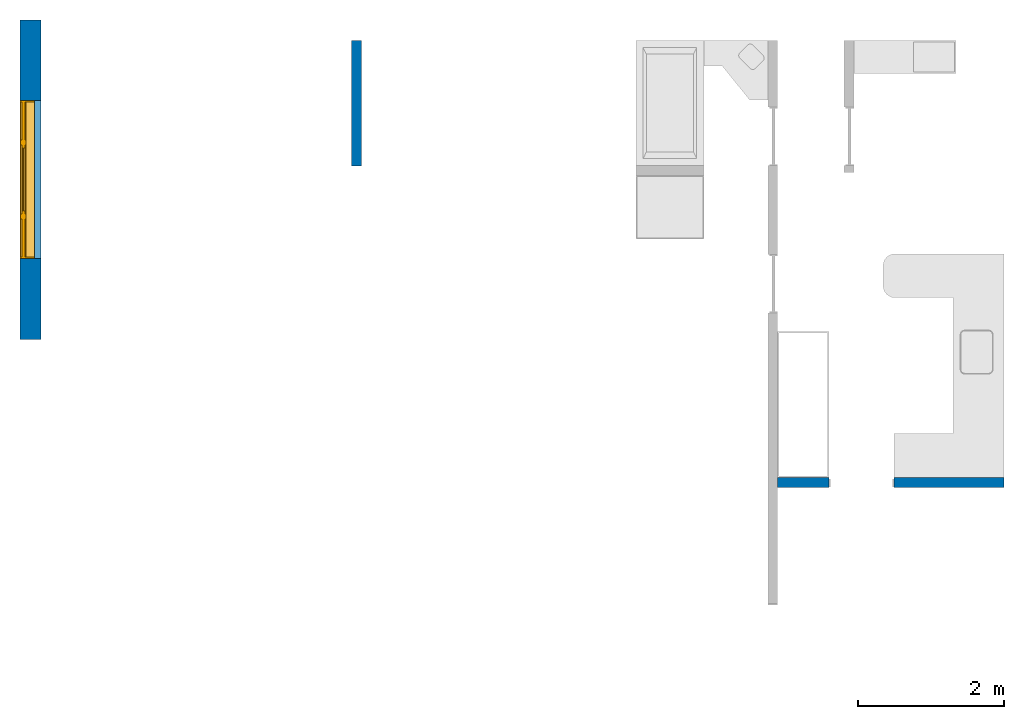
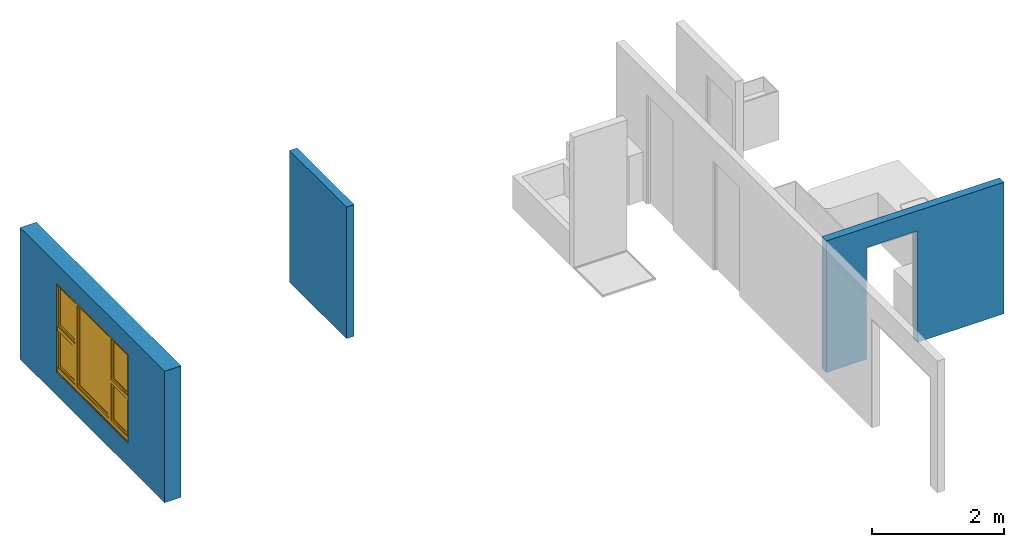
# One storey, part 1 of 6: 3 walls, 1 window, 2 openings.
"""IFC4 building model written with IfcOpenShell, lengths in millimetres."""

import ifcopenshell
import ifcopenshell.guid

model = None  # the IFC model being written
_history = None  # IfcOwnerHistory: only IFC2X3 demands one
_inside = {}  # id of a spatial element -> (the spatial element, [elements in it])
_under = {}  # id of a project, library or spatial element -> (it, [spatial elements below it])
_declared = {}  # id of a project -> (the project, [libraries it declares])
_typed = {}  # id of a type object -> (the type object, [elements of that type])
_made_of = {}  # id of a material, layer set ... -> (it, [elements and type objects made of it])


def new_model(schema):
    """Start an empty IFC model of exactly this schema.

    Asked for "IFC4X3", IfcOpenShell would pick the latest addendum, in which some entities
    have other attributes; the version numbers below select the first issue.
    IFC2X3 requires an IfcOwnerHistory on every rooted entity: one is made here for all.
    """
    global model, _history
    if schema == "IFC4X3":
        model = ifcopenshell.file(schema_version=(4, 3, 0, 0))
    else:
        model = ifcopenshell.file(schema=schema)
    _inside.clear()
    _under.clear()
    _declared.clear()
    _typed.clear()
    _made_of.clear()
    _history = None
    if model.schema == "IFC2X3":
        org = make("IfcOrganization", Name="unknown")
        user = make(
            "IfcPersonAndOrganization",
            ThePerson=make("IfcPerson", FamilyName="unknown"),
            TheOrganization=org,
        )
        app = make(
            "IfcApplication",
            ApplicationDeveloper=org,
            Version="unknown",
            ApplicationFullName="unknown",
            ApplicationIdentifier="unknown",
        )
        _history = make(
            "IfcOwnerHistory",
            OwningUser=user,
            OwningApplication=app,
            ChangeAction="ADDED",
            CreationDate=0,
        )
    return model


def make(cls, **values):
    """One entity of the class cls with the attributes given. An attribute that is None is left unset."""
    return model.create_entity(
        cls, **{name: value for name, value in values.items() if value is not None}
    )


def entity(cls, *values):
    """Any entity or typed value of the class cls, its attributes in the order of the schema. None: left unset."""
    e = model.create_entity(cls)
    for i, value in enumerate(values):
        if value is not None:
            e[i] = value
    return e


def rooted(cls, **values):
    """An entity with a GlobalId (a new one), such as an element, a storey or a relation."""
    return make(cls, GlobalId=ifcopenshell.guid.new(), OwnerHistory=_history, **values)


def si_unit(unit_type, name, prefix=None):
    """IfcSIUnit, for example si_unit("LENGTHUNIT", "METRE", prefix="MILLI")."""
    return make("IfcSIUnit", UnitType=unit_type, Prefix=prefix, Name=name)


def converted_unit(unit_type, name, factor, base, dimensions=None, offset=None):
    """IfcConversionBasedUnit, such as the inch: factor (a typed value) times the base unit."""
    return make(
        "IfcConversionBasedUnit"
        if offset is None
        else "IfcConversionBasedUnitWithOffset",
        ConversionOffset=offset,
        Dimensions=None
        if dimensions is None
        else entity("IfcDimensionalExponents", *dimensions),
        UnitType=unit_type,
        Name=name,
        ConversionFactor=make(
            "IfcMeasureWithUnit", ValueComponent=factor, UnitComponent=base
        ),
    )


def assignment(units):
    """IfcUnitAssignment: the units of a project."""
    return None if units is None else make("IfcUnitAssignment", Units=units)


def point(xyz):
    """IfcCartesianPoint."""
    return None if xyz is None else make("IfcCartesianPoint", Coordinates=xyz)


def direction(xyz):
    """IfcDirection."""
    return None if xyz is None else make("IfcDirection", DirectionRatios=xyz)


def frame(location, z_axis=None, x_axis=None):
    """IfcAxis2Placement3D, a coordinate frame: its origin and axes. An axis left out is left unset."""
    return make(
        "IfcAxis2Placement3D",
        Location=point(location),
        Axis=direction(z_axis),
        RefDirection=direction(x_axis),
    )


def frame_2d(location, x_axis=None):
    """IfcAxis2Placement2D, a coordinate frame in the plane: its origin and x axis."""
    return make(
        "IfcAxis2Placement2D", Location=point(location), RefDirection=direction(x_axis)
    )


def origin_with_axes():
    """The frame at (0, 0, 0) with the z axis (0, 0, 1) and the x axis (1, 0, 0) written out."""
    return frame((0.0, 0.0, 0.0), z_axis=(0.0, 0.0, 1.0), x_axis=(1.0, 0.0, 0.0))


def origin_2d_with_axis():
    """The frame at (0, 0) in the plane with the x axis (1, 0) written out."""
    return frame_2d((0.0, 0.0), x_axis=(1.0, 0.0))


def place(relative_to, where):
    """IfcLocalPlacement: puts the frame where relative to a parent placement (None: the world)."""
    return make(
        "IfcLocalPlacement", PlacementRelTo=relative_to, RelativePlacement=where
    )


def context(
    kind, dimensions, precision=None, world=None, true_north=None, identifier=None
):
    """IfcGeometricRepresentationContext, for example the 3D "Model" context."""
    return make(
        "IfcGeometricRepresentationContext",
        ContextIdentifier=identifier,
        ContextType=kind,
        CoordinateSpaceDimension=dimensions,
        Precision=precision,
        WorldCoordinateSystem=world,
        TrueNorth=true_north,
    )


def subcontext(parent, identifier, kind, view, scale=None):
    """IfcGeometricRepresentationSubContext, for example "Body" below "Model"."""
    return make(
        "IfcGeometricRepresentationSubContext",
        ContextIdentifier=identifier,
        ContextType=kind,
        ParentContext=parent,
        TargetScale=scale,
        TargetView=view,
    )


def project(units=None, contexts=None):
    """IfcProject with its units and contexts."""
    return rooted(
        "IfcProject",
        Name="project",
        RepresentationContexts=contexts,
        UnitsInContext=assignment(units),
    )


def spatial(cls, under=None, at=None, **own):
    """A site, building, storey or space (cls), placed at a placement, below another one or the project."""
    s = rooted(cls, ObjectPlacement=at, **own)
    if under is not None:
        _under.setdefault(under.id(), (under, []))[1].append(s)
    return s


def point_list(points):
    """IfcCartesianPointList2D or 3D."""
    cls = (
        "IfcCartesianPointList2D" if len(points[0]) == 2 else "IfcCartesianPointList3D"
    )
    return make(cls, CoordList=points)


def line(*indices):
    """IfcLineIndex: a straight run through numbered points of an indexed curve."""
    return model.create_entity("IfcLineIndex", indices)


def indexed_curve(points, segments=None, self_intersect=None):
    """IfcIndexedPolyCurve: lines and arcs through numbered points (the first is 1)."""
    return make(
        "IfcIndexedPolyCurve",
        Points=point_list(points),
        Segments=segments,
        SelfIntersect=self_intersect,
    )


def outline(outer, holes=None, kind="AREA"):
    """IfcArbitraryClosedProfileDef: a profile drawn as a closed curve; with holes, ...WithVoids."""
    if holes is None:
        return make("IfcArbitraryClosedProfileDef", ProfileType=kind, OuterCurve=outer)
    return make(
        "IfcArbitraryProfileDefWithVoids",
        ProfileType=kind,
        OuterCurve=outer,
        InnerCurves=holes,
    )


def extrude(swept, where, along, depth):
    """IfcExtrudedAreaSolid: the profile swept, set in the frame where, extruded along a direction by depth."""
    return make(
        "IfcExtrudedAreaSolid",
        SweptArea=swept,
        Position=where,
        ExtrudedDirection=direction(along),
        Depth=depth,
    )


def polygons(points, faces, closed=None, point_numbers=None):
    """IfcPolygonalFaceSet: a face is its outer loop, then its inner loops; points numbered from 1."""
    made = []
    for loops in faces:
        if len(loops) == 1:
            made.append(make("IfcIndexedPolygonalFace", CoordIndex=loops[0]))
        else:
            made.append(
                make(
                    "IfcIndexedPolygonalFaceWithVoids",
                    CoordIndex=loops[0],
                    InnerCoordIndices=loops[1:],
                )
            )
    return make(
        "IfcPolygonalFaceSet",
        Coordinates=point_list(points),
        Closed=closed,
        Faces=made,
        PnIndex=point_numbers,
    )


def shape(context_of_items, identifier, shape_type, items):
    """IfcShapeRepresentation: the items that make up one representation, for example the "Body"."""
    return make(
        "IfcShapeRepresentation",
        ContextOfItems=context_of_items,
        RepresentationIdentifier=identifier,
        RepresentationType=shape_type,
        Items=items,
    )


def source(mapping_origin, context_of_items, identifier, shape_type, items):
    """IfcRepresentationMap: a shape defined once, which mapped items show again and again."""
    return make(
        "IfcRepresentationMap",
        MappingOrigin=mapping_origin,
        MappedRepresentation=shape(context_of_items, identifier, shape_type, items),
    )


def transform(
    local_origin,
    x_axis=None,
    y_axis=None,
    z_axis=None,
    scale=None,
    scale2=None,
    scale3=None,
    uniform=True,
):
    """IfcCartesianTransformationOperator3D, or its non-uniform kind. x_axis, y_axis, z_axis: its Axis1, 2, 3."""
    if uniform:
        return make(
            "IfcCartesianTransformationOperator3D",
            Axis1=direction(x_axis),
            Axis2=direction(y_axis),
            LocalOrigin=point(local_origin),
            Scale=scale,
            Axis3=direction(z_axis),
        )
    return make(
        "IfcCartesianTransformationOperator3DnonUniform",
        Axis1=direction(x_axis),
        Axis2=direction(y_axis),
        LocalOrigin=point(local_origin),
        Scale=scale,
        Axis3=direction(z_axis),
        Scale2=scale2,
        Scale3=scale3,
    )


def mapped(mapping_source, mapping_target):
    """IfcMappedItem: shows the shape of a source again, moved by a transform."""
    return make(
        "IfcMappedItem", MappingSource=mapping_source, MappingTarget=mapping_target
    )


def material(Name=None, Category=None):
    """IfcMaterial."""
    return make("IfcMaterial", Name=Name, Category=Category)


def layer(
    of_material, thickness, ventilated=None, Name=None, Category=None, Priority=None
):
    """IfcMaterialLayer: one layer of a wall or slab, of a material (None: an air gap)."""
    return make(
        "IfcMaterialLayer",
        Material=of_material,
        LayerThickness=thickness,
        IsVentilated=ventilated,
        Name=Name,
        Category=Category,
        Priority=Priority,
    )


def layer_set(layers, Name=None):
    """IfcMaterialLayerSet."""
    return make("IfcMaterialLayerSet", MaterialLayers=layers, LayerSetName=Name)


def layer_usage(for_layer_set, set_direction, sense, offset, extent=None):
    """IfcMaterialLayerSetUsage: how a layer set lies in its element."""
    return make(
        "IfcMaterialLayerSetUsage",
        ForLayerSet=for_layer_set,
        LayerSetDirection=set_direction,
        DirectionSense=sense,
        OffsetFromReferenceLine=offset,
        ReferenceExtent=extent,
    )


def made_of(thing, what):
    """Note that an element or type object is made of a material, layer set ...; save() writes the relation."""
    if what is not None:
        _made_of.setdefault(what.id(), (what, []))[1].append(thing)
    return thing


def type_object(cls, material=None, **own):
    """A type object (cls), such as IfcWallType, which elements share."""
    return made_of(rooted(cls, **own), material)


def type_shapes(of_type, sources):
    """Give a type object the sources (RepresentationMaps) that its elements show as mapped items."""
    of_type.RepresentationMaps = sources


def element(
    cls,
    number,
    at=None,
    inside=None,
    cuts=None,
    type_object=None,
    material=None,
    context=None,
    identifier="Body",
    shape_type=None,
    held_by="IfcProductDefinitionShape",
    body=None,
    shapes=None,
    **own,
):
    """One element of the class cls, such as IfcWall. Its Tag is "e" and its number.

    at: its placement. inside: the storey or other place that contains it. cuts: it is an
    opening in that element (IfcRelVoidsElement). A single representation is given by context,
    identifier, shape_type and body (its items); several are given by shapes. held_by: the class
    of the entity that holds the representations. save() writes the other relations.
    """
    e = rooted(cls, Tag="e%d" % number, ObjectPlacement=at, **own)
    if body is not None:
        shapes = [shape(context, identifier, shape_type, body)]
    if shapes is not None:
        e.Representation = make(held_by, Representations=shapes)
    if inside is not None:
        _inside.setdefault(inside.id(), (inside, []))[1].append(e)
    if cuts is not None:
        rooted(
            "IfcRelVoidsElement", RelatingBuildingElement=cuts, RelatedOpeningElement=e
        )
    if type_object is not None:
        _typed.setdefault(type_object.id(), (type_object, []))[1].append(e)
    return made_of(e, material)


def fill(opening, filler):
    """IfcRelFillsElement: the door or window that sits in an opening."""
    return rooted(
        "IfcRelFillsElement",
        RelatingOpeningElement=opening,
        RelatedBuildingElement=filler,
    )


def aggregate(whole, parts):
    """IfcRelAggregates: a whole, such as a stair, and the parts it consists of."""
    return rooted("IfcRelAggregates", RelatingObject=whole, RelatedObjects=parts)


def save(model, path):
    """Write the relations noted so far, then the file.

    IfcRelAggregates (storeys below a building ...), IfcRelContainedInSpatialStructure (elements
    in a storey), IfcRelDefinesByType, IfcRelAssociatesMaterial and IfcRelDeclares: one each for
    every whole, place, type object, material and project.
    """
    for whole, parts in _under.values():
        aggregate(whole, parts)
    for where, things in _inside.values():
        rooted(
            "IfcRelContainedInSpatialStructure",
            RelatedElements=things,
            RelatingStructure=where,
        )
    for kind, things in _typed.values():
        rooted("IfcRelDefinesByType", RelatedObjects=things, RelatingType=kind)
    for what, things in _made_of.values():
        rooted("IfcRelAssociatesMaterial", RelatedObjects=things, RelatingMaterial=what)
    for by, libraries in _declared.values():
        rooted("IfcRelDeclares", RelatingContext=by, RelatedDefinitions=libraries)
    model.write(path)


model = new_model("IFC4")

# Units and contexts
model_context = context("Model", 3, precision=1e-05, world=origin_with_axes())
plan_context = context("Plan", 2, precision=1e-05, world=origin_2d_with_axis())
body_context = subcontext(model_context, "Body", "Model", "MODEL_VIEW")
ifc_project = project(units=[si_unit("VOLUMEUNIT", "CUBIC_METRE"), si_unit("LENGTHUNIT", "METRE", prefix="MILLI"), converted_unit("PLANEANGLEUNIT", "degree", entity("IfcReal", 0.0174532925199433), si_unit("PLANEANGLEUNIT", "RADIAN"), dimensions=[0, 0, 0, 0, 0, 0, 0]), si_unit("AREAUNIT", "SQUARE_METRE")], contexts=[model_context, plan_context])

# Site, building, storey
site_placement = place(None, origin_with_axes())
site = spatial("IfcSite", under=ifc_project, at=site_placement)
building_placement = place(site_placement, origin_with_axes())
building = spatial("IfcBuilding", under=site, at=building_placement, Name="Building")
storey_placement = place(building_placement, origin_with_axes())
storey = spatial("IfcBuildingStorey", under=building, at=storey_placement, Name="DEMO")

# Wall
ifc_material = material()
ifc_layer_1 = layer(ifc_material, 135.0)
ifc_layer_set_1 = layer_set([ifc_layer_1])
ifc_layer_usage_1 = layer_usage(ifc_layer_set_1, "AXIS2", "POSITIVE", 0.0)
wall_type_1 = type_object("IfcWallType", Name="WAL135", PredefinedType="NOTDEFINED", material=ifc_layer_set_1)
wall_1_placement = place(storey_placement, frame((4284.11769866943, 5461.66658401489, 0.0), z_axis=(0.0, 0.0, 1.0), x_axis=(3.13916473260163e-07, -0.999999999999951, 0.0)))
element("IfcWall", 1, at=wall_1_placement, inside=storey, type_object=wall_type_1, material=ifc_layer_usage_1, Name="Wall", context=body_context, shape_type="SweptSolid", body=[
    extrude(outline(indexed_curve([(0.0, 0.0), (0.0, 135.0), (1719.99979529275, 135.0), (1719.99979529275, 0.0), (0.0, 0.0)], self_intersect=False)), origin_with_axes(), (0.0, 0.0, 1.0), 2425.00019073486),
])

# Wall, opening
ifc_layer_usage_2 = layer_usage(ifc_layer_set_1, "AXIS2", "POSITIVE", 0.0)
wall_2_placement = place(storey_placement, frame((10114.1214370728, -653.332471847534, 0.0), z_axis=(0.0, 0.0, 1.0), x_axis=(0.999999999999993, 1.19209282445353e-07, 0.0)))
wall_2 = element("IfcWall", 2, at=wall_2_placement, inside=storey, type_object=wall_type_1, material=ifc_layer_usage_2, Name="Wall", context=body_context, shape_type="SweptSolid", body=[
    extrude(outline(indexed_curve([(0.0, 0.0), (0.0, 135.0), (3094.9992730505, 135.0), (3094.9992730505, 0.0), (0.0, 0.0)], self_intersect=False)), origin_with_axes(), (0.0, 0.0, 1.0), 2425.00019073486),
])
shared_shape_1 = source(origin_with_axes(), body_context, "Body", "SweptSolid", [
    extrude(outline(indexed_curve([(0.0, 0.0), (890.001281738281, 0.0), (890.001281738281, 2055.0), (0.0, 2055.0)], segments=[line(1, 2, 3, 4, 1)])), frame((2.38418564890708e-07, -600.0, 0.0), z_axis=(0.0, -1.0, 0.0), x_axis=(1.0, 0.0, 0.0)), (0.0, 0.0, -1.0), 1200.0),
])
opening_1_placement = place(wall_2_placement, frame((699.99984382384, 63.0001493304366, 0.0), z_axis=(0.0, 0.0, 1.0), x_axis=(0.999999999999993, 1.19209282445351e-07, 0.0)))
element("IfcOpeningElement", 3, at=opening_1_placement, cuts=wall_2, PredefinedType="OPENING", context=body_context, shape_type="MappedRepresentation", body=[
    mapped(shared_shape_1, transform((0.0, 0.0, 0.0), x_axis=(1.0, 0.0, 0.0), y_axis=(0.0, 1.0, 0.0), z_axis=(0.0, 0.0, 1.0), scale=1.0)),
])

# Wall, opening, window
ifc_layer_2 = layer(ifc_material, 285.0, Name="brick")
ifc_layer_set_2 = layer_set([ifc_layer_2])
ifc_layer_usage_3 = layer_usage(ifc_layer_set_2, "AXIS2", "POSITIVE", 0.0)
wall_type_2 = type_object("IfcWallType", Name="285mm Wall", PredefinedType="STANDARD", material=ifc_layer_set_2)
wall_3_placement = place(storey_placement, frame((34.119613468647, 1371.66702747345, 0.0), z_axis=(0.0, 0.0, 1.0), x_axis=(3.13916473260163e-07, 0.999999999999951, 0.0)))
wall_3 = element("IfcWall", 4, at=wall_3_placement, inside=storey, type_object=wall_type_2, material=ifc_layer_usage_3, Name="Wall", context=body_context, shape_type="SweptSolid", body=[
    extrude(outline(indexed_curve([(0.0, 0.0), (0.0, 285.0), (4368.4482017261, 285.0), (4368.4482017261, 0.0), (0.0, 0.0)], self_intersect=False)), origin_with_axes(), (0.0, 0.0, 1.0), 2425.00019073486),
])
shared_shape_2 = source(origin_with_axes(), body_context, "Body", "SweptSolid", [
    extrude(outline(indexed_curve([(0.0, 0.0), (2165.00024414062, 0.0), (2165.00024414062, 1629.99987792969), (0.0, 1629.99987792969)], segments=[line(1, 2, 3, 4, 1)])), frame((-1.04308121251506e-07, -600.0, 0.0), z_axis=(0.0, -1.0, 0.0), x_axis=(1.0, 0.0, 0.0)), (0.0, 0.0, -1.0), 1200.0),
])
opening_2_placement = place(wall_3_placement, frame((1105.00133037573, 4.26122824526143e-07, 430.000007152557), z_axis=(0.0, 0.0, 1.0), x_axis=(1.0, 0.0, 0.0)))
opening_2 = element("IfcOpeningElement", 5, at=opening_2_placement, cuts=wall_3, Name="Opening", PredefinedType="OPENING", context=body_context, shape_type="MappedRepresentation", body=[
    mapped(shared_shape_2, transform((0.0, 0.0, 0.0), x_axis=(1.0, 0.0, 0.0), y_axis=(0.0, 1.0, 0.0), z_axis=(0.0, 0.0, 1.0), scale=1.0)),
])
window_type = type_object("IfcWindowType", Name="Ex.2165x1630", PartitioningType="NOTDEFINED", PredefinedType="WINDOW")
shared_shape_3 = source(origin_with_axes(), body_context, "Body", "Tessellation", [
    polygons([(2165.00048828125, -148.88883972168, 0.0), (2165.00048828125, -148.88883972168, 19.9999198913574), (0.000134110436192714, -148.888961791992, 0.0), (0.000134110436192714, -148.888961791992, 19.9999198913574), (2165.00048828125, 51.1111831665039, 0.0), (2165.00048828125, 51.1111831665039, 19.9999198913574), (0.000134110436192714, 51.1110649108887, 0.0), (0.000134110436192714, 51.1110649108887, 19.9999198913574), (2165.00048828125, -148.88883972168, 1609.99975585938), (2165.00048828125, -148.88883972168, 1630.0), (0.000134110436192714, -148.888961791992, 1609.99975585938), (0.000134110436192714, -148.888961791992, 1630.0), (2165.00048828125, 51.1111831665039, 1609.99975585938), (2165.00048828125, 51.1111831665039, 1630.0), (0.000134110436192714, 51.1110649108887, 1609.99975585938), (0.000134110436192714, 51.1110649108887, 1630.0), (0.000134110436192714, -148.88883972168, 19.9999198913574), (20.0003528594971, -148.88883972168, 19.9999198913574), (0.000134110436192714, -148.888961791992, 1609.99975585938), (20.000114440918, -148.888961791992, 1609.99975585938), (0.000134110436192714, 51.1111831665039, 19.9999198913574), (20.000114440918, 51.1111831665039, 19.9999198913574), (-0.000104308121080976, 51.1110649108887, 1609.99975585938), (20.000114440918, 51.1110649108887, 1609.99975585938), (2145.00048828125, -148.88883972168, 19.9999198913574), (2165.00048828125, -148.88883972168, 19.9999198913574), (2145.0, -148.888961791992, 1609.99975585938), (2165.0, -148.888961791992, 1609.99975585938), (2145.00048828125, 51.1111831665039, 19.9999198913574), (2165.00048828125, 51.1111831665039, 19.9999198913574), (2145.0, 51.1110649108887, 1609.99975585938), (2165.0, 51.1110649108887, 1609.99975585938), (1554.99987792969, -28.8888530731201, 19.9999198913574), (1625.0, -28.8888530731201, 19.9999198913574), (1554.99938964844, -28.8888530731201, 1609.99975585938), (1624.99951171875, -28.8888530731201, 1609.99975585938), (1554.99987792969, 41.1110763549805, 19.9999198913574), (1625.0, 41.1110763549805, 19.9999198913574), (1554.99938964844, 41.1110763549805, 1609.99975585938), (1624.99951171875, 41.1110763549805, 1609.99975585938), (540.000061035156, -28.8888530731201, 19.9999198913574), (610.000244140625, -28.8888530731201, 19.9999198913574), (539.999816894531, -28.8888530731201, 1609.99975585938), (610.0, -28.8888530731201, 1609.99975585938), (540.000061035156, 41.1110763549805, 19.9999198913574), (610.000244140625, 41.1110763549805, 19.9999198913574), (539.999816894531, 41.1110763549805, 1609.99975585938), (610.0, 41.1110763549805, 1609.99975585938), (20.000114440918, -28.888973236084, 844.999328613281), (20.000114440918, -28.888973236084, 775.000122070312), (540.000061035156, -28.8888530731201, 845.000061035156), (540.000061035156, -28.8888530731201, 775.000793457031), (20.000114440918, 41.1110763549805, 844.999328613281), (20.000114440918, 41.1110763549805, 775.000122070312), (540.000061035156, 41.1110763549805, 845.000061035156), (540.000061035156, 41.1111946105957, 775.000793457031), (1625.0, -28.888973236084, 844.999328613281), (1625.0, -28.888973236084, 775.000122070312), (2145.0, -28.8888530731201, 845.000061035156), (2145.0, -28.8888530731201, 775.000793457031), (1625.0, 41.1110763549805, 844.999328613281), (1625.0, 41.1110763549805, 775.000122070312), (2145.0, 41.1110763549805, 845.000061035156), (2145.0, 41.1111946105957, 775.000793457031), (1625.0, -13.8889875411987, 1609.99951171875), (1625.0, -13.8889875411987, 1569.99987792969), (2145.0, -13.8888683319092, 1609.99975585938), (2145.0, -13.8888683319092, 1570.00061035156), (1625.0, 26.1110916137695, 1609.99951171875), (1625.0, 26.1110916137695, 1569.99987792969), (2145.0, 26.1110916137695, 1610.00024414062), (2145.0, 26.1110916137695, 1570.00061035156), (1625.0, -13.8889875411987, 884.9990234375), (1625.0, -13.8889875411987, 844.999328613281), (2145.0, -13.8888683319092, 884.99951171875), (2145.0, -13.8888683319092, 844.999938964844), (1625.0, 26.1110916137695, 884.9990234375), (1625.0, 26.1110916137695, 844.999328613281), (2145.0, 26.1110916137695, 884.99951171875), (2145.0, 26.1110916137695, 844.999938964844), (1665.0, -13.8888683319092, 1570.00012207031), (1625.0, -13.8888683319092, 1570.00012207031), (1664.99975585938, -13.8888683319092, 884.9990234375), (1625.0, -13.8888683319092, 884.9990234375), (1665.0, 26.1110916137695, 1570.00012207031), (1625.0, 26.1110916137695, 1570.00012207031), (1664.99975585938, 26.1110916137695, 884.9990234375), (1625.0, 26.1110916137695, 884.9990234375), (2144.99951171875, -13.8888683319092, 1570.00012207031), (2105.00024414062, -13.8888683319092, 1570.00012207031), (2144.99951171875, -13.8888683319092, 884.9990234375), (2104.99975585938, -13.8888683319092, 884.9990234375), (2144.99951171875, 26.1110916137695, 1570.00012207031), (2105.00024414062, 26.1110916137695, 1570.00012207031), (2144.99951171875, 26.1110916137695, 884.9990234375), (2104.99975585938, 26.1110916137695, 884.9990234375), (20.0003528594971, -13.8889875411987, 1609.99951171875), (20.0003528594971, -13.8889875411987, 1569.99987792969), (540.000305175781, -13.8888683319092, 1609.99975585938), (540.000305175781, -13.8888683319092, 1570.00061035156), (20.0003528594971, 26.1110916137695, 1609.99951171875), (20.0003528594971, 26.1110916137695, 1569.99987792969), (540.000305175781, 26.1110916137695, 1610.00024414062), (540.000305175781, 26.1110916137695, 1570.00061035156), (20.0003528594971, -13.8889875411987, 884.9990234375), (20.0003528594971, -13.8889875411987, 844.999328613281), (540.000305175781, -13.8888683319092, 884.99951171875), (540.000305175781, -13.8888683319092, 844.999938964844), (20.0003528594971, 26.1110916137695, 884.9990234375), (20.0003528594971, 26.1110916137695, 844.999328613281), (540.000305175781, 26.1110916137695, 884.99951171875), (540.000305175781, 26.1110916137695, 844.999938964844), (60.0003128051758, -13.8888683319092, 1570.00012207031), (20.0005912780762, -13.8888683319092, 1570.00012207031), (60.000072479248, -13.8888683319092, 884.9990234375), (20.0005912780762, -13.8888683319092, 884.9990234375), (60.0003128051758, 26.1110916137695, 1570.00012207031), (20.0005912780762, 26.1110916137695, 1570.00012207031), (60.000072479248, 26.1110916137695, 884.9990234375), (20.0005912780762, 26.1110916137695, 884.9990234375), (539.999572753906, -13.8888683319092, 1570.00012207031), (499.999847412109, -13.8888683319092, 1570.00012207031), (539.999572753906, -13.8888683319092, 884.9990234375), (499.999603271484, -13.8888683319092, 884.9990234375), (539.999572753906, 26.1110916137695, 1570.00012207031), (499.999847412109, 26.1110916137695, 1570.00012207031), (539.999572753906, 26.1110916137695, 884.9990234375), (499.999603271484, 26.1110916137695, 884.9990234375), (20.000114440918, -28.888973236084, 89.9992523193359), (20.000114440918, -28.888973236084, 19.9997406005859), (540.000061035156, -28.8888530731201, 89.9999694824219), (540.000061035156, -28.8888530731201, 20.0004558563232), (20.000114440918, 41.1110763549805, 89.9992523193359), (20.000114440918, 41.1110763549805, 19.9997406005859), (540.000061035156, 41.1110763549805, 89.9999694824219), (540.000061035156, 41.1111946105957, 20.0004558563232), (1625.0, -28.888973236084, 89.9992523193359), (1625.0, -28.888973236084, 19.9997406005859), (2145.0, -28.8888530731201, 89.9999694824219), (2145.0, -28.8888530731201, 20.0004558563232), (1625.0, 41.1110763549805, 89.9992523193359), (1625.0, 41.1110763549805, 19.9997406005859), (2145.0, 41.1110763549805, 89.9999694824219), (2145.0, 41.1111946105957, 20.0004558563232), (610.000244140625, -28.888973236084, 89.9992523193359), (610.000244140625, -28.888973236084, 19.9997406005859), (1554.99987792969, -28.8888530731201, 89.9999694824219), (1554.99987792969, -28.8888530731201, 20.0004558563232), (610.000244140625, 41.1110763549805, 89.9992523193359), (610.000244140625, 41.1110763549805, 19.9997406005859), (1554.99987792969, 41.1110763549805, 89.9999694824219), (1554.99987792969, 41.1110763549805, 20.0004558563232), (1625.0, -13.8889875411987, 775.000244140625), (1625.0, -13.8889875411987, 735.000366210938), (2145.0, -13.8888683319092, 775.000793457031), (2145.0, -13.8888683319092, 735.001098632812), (1625.0, 26.1110916137695, 775.000244140625), (1625.0, 26.1110916137695, 735.000366210938), (2145.0, 26.1110916137695, 775.000793457031), (2145.0, 26.1110916137695, 735.001098632812), (1625.0, -13.8889875411987, 129.999694824219), (1625.0, -13.8889875411987, 89.9999694824219), (2145.0, -13.8888683319092, 130.00016784668), (2145.0, -13.8888683319092, 90.0005645751953), (1625.0, 26.1110916137695, 129.999694824219), (1625.0, 26.1110916137695, 89.9999694824219), (2145.0, 26.1110916137695, 130.00016784668), (2145.0, 26.1110916137695, 90.0005645751953), (1665.0, -13.8888683319092, 735.000610351562), (1625.0, -13.8888683319092, 735.000610351562), (1664.99975585938, -13.8888683319092, 129.998977661133), (1625.0, -13.8888683319092, 129.999099731445), (1665.0, 26.1110916137695, 735.000610351562), (1625.0, 26.1110916137695, 735.000610351562), (1664.99975585938, 26.1110916137695, 129.998977661133), (1625.0, 26.1110916137695, 129.999099731445), (2144.99951171875, -13.8888683319092, 735.000610351562), (2105.00024414062, -13.8888683319092, 735.000610351562), (2144.99951171875, -13.8888683319092, 129.998977661133), (2104.99975585938, -13.8888683319092, 129.999099731445), (2144.99951171875, 26.1110916137695, 735.000610351562), (2105.00024414062, 26.1110916137695, 735.000610351562), (2144.99951171875, 26.1110916137695, 129.998977661133), (2104.99975585938, 26.1110916137695, 129.999099731445), (20.0003528594971, -13.8889875411987, 775.000244140625), (20.0003528594971, -13.8889875411987, 735.000366210938), (540.000305175781, -13.8888683319092, 775.000793457031), (540.000305175781, -13.8888683319092, 735.001098632812), (20.0003528594971, 26.1110916137695, 775.000244140625), (20.0003528594971, 26.1110916137695, 735.000366210938), (540.000305175781, 26.1110916137695, 775.000793457031), (540.000305175781, 26.1110916137695, 735.001098632812), (20.0003528594971, -13.8889875411987, 129.998611450195), (20.0003528594971, -13.8889875411987, 89.9989547729492), (540.000305175781, -13.8888683319092, 129.999099731445), (540.000305175781, -13.8888683319092, 89.9994354248047), (20.0003528594971, 26.1110916137695, 129.998611450195), (20.0003528594971, 26.1110916137695, 89.9989547729492), (540.000305175781, 26.1110916137695, 129.999206542969), (540.000305175781, 26.1110916137695, 89.9994354248047), (60.0003128051758, -13.8888683319092, 735.000610351562), (20.0005912780762, -13.8888683319092, 735.000610351562), (60.000072479248, -13.8888683319092, 129.998977661133), (20.0005912780762, -13.8888683319092, 129.999099731445), (60.0003128051758, 26.1110916137695, 735.000610351562), (20.0005912780762, 26.1110916137695, 735.000610351562), (60.000072479248, 26.1110916137695, 129.998977661133), (20.0005912780762, 26.1110916137695, 129.999099731445), (539.999572753906, -13.8888683319092, 735.000610351562), (499.999847412109, -13.8888683319092, 735.000610351562), (539.999572753906, -13.8888683319092, 129.998977661133), (499.999603271484, -13.8888683319092, 129.999099731445), (539.999572753906, 26.1110916137695, 735.000610351562), (499.999847412109, 26.1110916137695, 735.000610351562), (539.999572753906, 26.1110916137695, 129.998977661133), (499.999603271484, 26.1110916137695, 129.999099731445), (610.000427246094, -13.8889875411987, 1609.99951171875), (610.000427246094, -13.8889875411987, 1569.99987792969), (1554.99987792969, -13.8888683319092, 1609.99975585938), (1554.99987792969, -13.8888683319092, 1570.00061035156), (610.000427246094, 26.1110916137695, 1609.99951171875), (610.000427246094, 26.1110916137695, 1569.99987792969), (1554.99987792969, 26.1110916137695, 1610.00024414062), (1554.99987792969, 26.1110916137695, 1570.00061035156), (610.000427246094, -13.8889875411987, 129.998916625977), (610.000427246094, -13.8889875411987, 89.9992523193359), (1554.99987792969, -13.8888683319092, 129.999389648438), (1554.99987792969, -13.8888683319092, 89.9997863769531), (610.000427246094, 26.1110916137695, 129.998916625977), (610.000427246094, 26.1110916137695, 89.9992523193359), (1554.99987792969, 26.1110916137695, 129.999389648438), (1554.99987792969, 26.1110916137695, 89.9997863769531), (650.000183105469, -13.8888683319092, 1570.00012207031), (610.000671386719, -13.8888683319092, 1570.00012207031), (650.000183105469, -13.8888683319092, 129.999572753906), (610.000427246094, -13.8888683319092, 129.999572753906), (650.000183105469, 26.1110916137695, 1570.00012207031), (610.000671386719, 26.1110916137695, 1570.00012207031), (650.000183105469, 26.1110916137695, 129.999572753906), (610.000427246094, 26.1110916137695, 129.999572753906), (1554.99987792969, -13.8888683319092, 1570.00012207031), (1515.00012207031, -13.8888683319092, 1570.00012207031), (1554.99987792969, -13.8888683319092, 129.999389648438), (1515.00012207031, -13.8888683319092, 129.999389648438), (1554.99987792969, 26.1110916137695, 1570.00012207031), (1515.00012207031, 26.1110916137695, 1570.00012207031), (1554.99987792969, 26.1110916137695, 129.999389648438), (1515.00012207031, 26.1110916137695, 129.999389648438), (1515.00012207031, 1.11111617088318, 1570.00012207031), (650.001586914062, 1.11111617088318, 1570.00012207031), (1515.00012207031, 1.11111617088318, 129.999450683594), (650.001342773438, 1.11111617088318, 129.999572753906), (1515.00012207031, 11.1111059188843, 1570.00012207031), (650.001586914062, 11.1111059188843, 1570.00012207031), (1515.00012207031, 11.1111059188843, 129.999450683594), (650.001342773438, 11.1111059188843, 129.999572753906), (2104.99877929688, 1.11111617088318, 1570.00012207031), (1665.0, 1.11111617088318, 1570.00012207031), (2104.99877929688, 1.11111617088318, 884.99951171875), (1664.99975585938, 1.11111617088318, 884.99951171875), (2104.99877929688, 11.1111059188843, 1570.00012207031), (1665.0, 11.1111059188843, 1570.00012207031), (2104.99877929688, 11.1111059188843, 884.99951171875), (1664.99975585938, 11.1111059188843, 884.99951171875), (2104.99877929688, 1.11111617088318, 735.000366210938), (1665.0, 1.11111617088318, 735.000610351562), (2104.99877929688, 1.11111617088318, 130.000518798828), (1664.99975585938, 1.11111617088318, 130.000518798828), (2104.99877929688, 11.1111059188843, 735.000366210938), (1665.0, 11.1111059188843, 735.000610351562), (2104.99877929688, 11.1111059188843, 130.000518798828), (1664.99975585938, 11.1111059188843, 130.000518798828), (499.998901367188, 1.11111617088318, 1570.00012207031), (60.0003128051758, 1.11111617088318, 1570.00012207031), (499.998657226562, 1.11111617088318, 884.99951171875), (60.000072479248, 1.11111617088318, 884.99951171875), (499.998901367188, 11.1111059188843, 1570.00012207031), (60.0003128051758, 11.1111059188843, 1570.00012207031), (499.998657226562, 11.1111059188843, 884.99951171875), (60.000072479248, 11.1111059188843, 884.99951171875), (499.998901367188, 1.11111617088318, 735.000366210938), (60.0003128051758, 1.11111617088318, 735.000610351562), (499.998657226562, 1.11111617088318, 130.000518798828), (60.000072479248, 1.11111617088318, 130.000518798828), (499.998901367188, 11.1111059188843, 735.000366210938), (60.0003128051758, 11.1111059188843, 735.000610351562), (499.998657226562, 11.1111059188843, 130.000518798828), (60.000072479248, 11.1111059188843, 130.000518798828)], [[[1, 2, 4, 3]], [[3, 4, 8, 7]], [[7, 8, 6, 5]], [[5, 6, 2, 1]], [[3, 7, 5, 1]], [[8, 4, 2, 6]], [[9, 10, 12, 11]], [[11, 12, 16, 15]], [[15, 16, 14, 13]], [[13, 14, 10, 9]], [[11, 15, 13, 9]], [[16, 12, 10, 14]], [[17, 18, 20, 19]], [[19, 20, 24, 23]], [[23, 24, 22, 21]], [[21, 22, 18, 17]], [[19, 23, 21, 17]], [[24, 20, 18, 22]], [[25, 26, 28, 27]], [[27, 28, 32, 31]], [[31, 32, 30, 29]], [[29, 30, 26, 25]], [[27, 31, 29, 25]], [[32, 28, 26, 30]], [[33, 34, 36, 35]], [[35, 36, 40, 39]], [[39, 40, 38, 37]], [[37, 38, 34, 33]], [[35, 39, 37, 33]], [[40, 36, 34, 38]], [[41, 42, 44, 43]], [[43, 44, 48, 47]], [[47, 48, 46, 45]], [[45, 46, 42, 41]], [[43, 47, 45, 41]], [[48, 44, 42, 46]], [[49, 50, 52, 51]], [[51, 52, 56, 55]], [[55, 56, 54, 53]], [[53, 54, 50, 49]], [[51, 55, 53, 49]], [[56, 52, 50, 54]], [[57, 58, 60, 59]], [[59, 60, 64, 63]], [[63, 64, 62, 61]], [[61, 62, 58, 57]], [[59, 63, 61, 57]], [[64, 60, 58, 62]], [[65, 66, 68, 67]], [[67, 68, 72, 71]], [[71, 72, 70, 69]], [[69, 70, 66, 65]], [[67, 71, 69, 65]], [[72, 68, 66, 70]], [[73, 74, 76, 75]], [[75, 76, 80, 79]], [[79, 80, 78, 77]], [[77, 78, 74, 73]], [[75, 79, 77, 73]], [[80, 76, 74, 78]], [[81, 82, 84, 83]], [[83, 84, 88, 87]], [[87, 88, 86, 85]], [[85, 86, 82, 81]], [[83, 87, 85, 81]], [[88, 84, 82, 86]], [[89, 90, 92, 91]], [[91, 92, 96, 95]], [[95, 96, 94, 93]], [[93, 94, 90, 89]], [[91, 95, 93, 89]], [[96, 92, 90, 94]], [[97, 98, 100, 99]], [[99, 100, 104, 103]], [[103, 104, 102, 101]], [[101, 102, 98, 97]], [[99, 103, 101, 97]], [[104, 100, 98, 102]], [[105, 106, 108, 107]], [[107, 108, 112, 111]], [[111, 112, 110, 109]], [[109, 110, 106, 105]], [[107, 111, 109, 105]], [[112, 108, 106, 110]], [[113, 114, 116, 115]], [[115, 116, 120, 119]], [[119, 120, 118, 117]], [[117, 118, 114, 113]], [[115, 119, 117, 113]], [[120, 116, 114, 118]], [[121, 122, 124, 123]], [[123, 124, 128, 127]], [[127, 128, 126, 125]], [[125, 126, 122, 121]], [[123, 127, 125, 121]], [[128, 124, 122, 126]], [[129, 130, 132, 131]], [[131, 132, 136, 135]], [[135, 136, 134, 133]], [[133, 134, 130, 129]], [[131, 135, 133, 129]], [[136, 132, 130, 134]], [[137, 138, 140, 139]], [[139, 140, 144, 143]], [[143, 144, 142, 141]], [[141, 142, 138, 137]], [[139, 143, 141, 137]], [[144, 140, 138, 142]], [[145, 146, 148, 147]], [[147, 148, 152, 151]], [[151, 152, 150, 149]], [[149, 150, 146, 145]], [[147, 151, 149, 145]], [[152, 148, 146, 150]], [[153, 154, 156, 155]], [[155, 156, 160, 159]], [[159, 160, 158, 157]], [[157, 158, 154, 153]], [[155, 159, 157, 153]], [[160, 156, 154, 158]], [[161, 162, 164, 163]], [[163, 164, 168, 167]], [[167, 168, 166, 165]], [[165, 166, 162, 161]], [[163, 167, 165, 161]], [[168, 164, 162, 166]], [[169, 170, 172, 171]], [[171, 172, 176, 175]], [[175, 176, 174, 173]], [[173, 174, 170, 169]], [[171, 175, 173, 169]], [[176, 172, 170, 174]], [[177, 178, 180, 179]], [[179, 180, 184, 183]], [[183, 184, 182, 181]], [[181, 182, 178, 177]], [[179, 183, 181, 177]], [[184, 180, 178, 182]], [[185, 186, 188, 187]], [[187, 188, 192, 191]], [[191, 192, 190, 189]], [[189, 190, 186, 185]], [[187, 191, 189, 185]], [[192, 188, 186, 190]], [[193, 194, 196, 195]], [[195, 196, 200, 199]], [[199, 200, 198, 197]], [[197, 198, 194, 193]], [[195, 199, 197, 193]], [[200, 196, 194, 198]], [[201, 202, 204, 203]], [[203, 204, 208, 207]], [[207, 208, 206, 205]], [[205, 206, 202, 201]], [[203, 207, 205, 201]], [[208, 204, 202, 206]], [[209, 210, 212, 211]], [[211, 212, 216, 215]], [[215, 216, 214, 213]], [[213, 214, 210, 209]], [[211, 215, 213, 209]], [[216, 212, 210, 214]], [[217, 218, 220, 219]], [[219, 220, 224, 223]], [[223, 224, 222, 221]], [[221, 222, 218, 217]], [[219, 223, 221, 217]], [[224, 220, 218, 222]], [[225, 226, 228, 227]], [[227, 228, 232, 231]], [[231, 232, 230, 229]], [[229, 230, 226, 225]], [[227, 231, 229, 225]], [[232, 228, 226, 230]], [[233, 234, 236, 235]], [[235, 236, 240, 239]], [[239, 240, 238, 237]], [[237, 238, 234, 233]], [[235, 239, 237, 233]], [[240, 236, 234, 238]], [[241, 242, 244, 243]], [[243, 244, 248, 247]], [[247, 248, 246, 245]], [[245, 246, 242, 241]], [[243, 247, 245, 241]], [[248, 244, 242, 246]], [[249, 250, 252, 251]], [[251, 252, 256, 255]], [[255, 256, 254, 253]], [[253, 254, 250, 249]], [[251, 255, 253, 249]], [[256, 252, 250, 254]], [[257, 258, 260, 259]], [[259, 260, 264, 263]], [[263, 264, 262, 261]], [[261, 262, 258, 257]], [[259, 263, 261, 257]], [[264, 260, 258, 262]], [[265, 266, 268, 267]], [[267, 268, 272, 271]], [[271, 272, 270, 269]], [[269, 270, 266, 265]], [[267, 271, 269, 265]], [[272, 268, 266, 270]], [[273, 274, 276, 275]], [[275, 276, 280, 279]], [[279, 280, 278, 277]], [[277, 278, 274, 273]], [[275, 279, 277, 273]], [[280, 276, 274, 278]], [[281, 282, 284, 283]], [[283, 284, 288, 287]], [[287, 288, 286, 285]], [[285, 286, 282, 281]], [[283, 287, 285, 281]], [[288, 284, 282, 286]]], closed=True),
])
type_shapes(window_type, [shared_shape_3])
window_placement = place(opening_2_placement, frame((-0.000550259744436232, 233.892109244901, 0.0), z_axis=(0.0, 0.0, 1.0), x_axis=(1.0, 0.0, 0.0)))
window = element("IfcWindow", 6, at=window_placement, inside=storey, type_object=window_type, Name="Window", context=body_context, shape_type="MappedRepresentation", body=[
    mapped(shared_shape_3, transform((0.0, 0.0, 0.0), x_axis=(1.0, 0.0, 0.0), y_axis=(0.0, 1.0, 0.0), z_axis=(0.0, 0.0, 1.0), scale=1.0)),
])
fill(opening_2, window)

save(model, "model.ifc")
